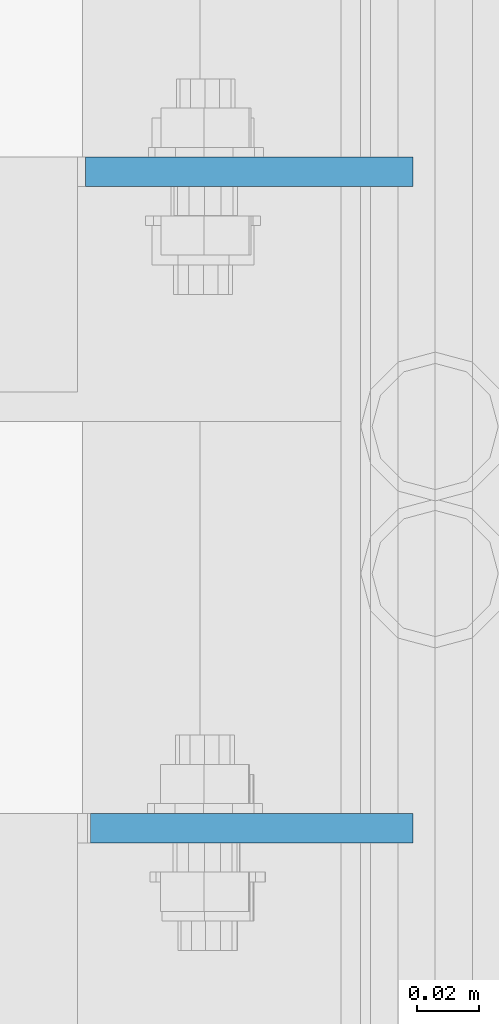
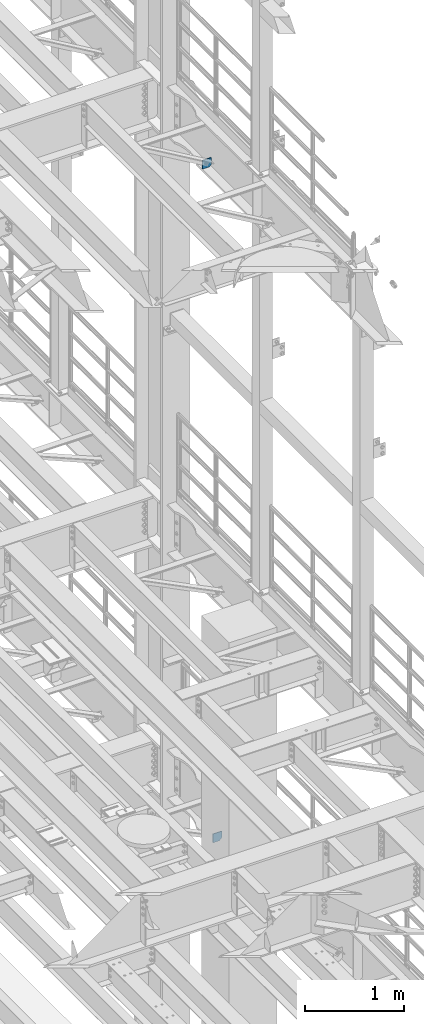
# One storey, part 1728 of 1876: 2 plates, 2 elements without a shape of their own.
"""IFC2X3 building model written with IfcOpenShell, lengths in millimetres."""

from ifc_helpers import new_model, si_unit, frame, origin_with_axes, place, context, subcontext, project, spatial, faceted_brep, material, type_object, element, aggregate, save


model = new_model("IFC2X3")

# Units and contexts
model_context = context("Model", 3, precision=1e-05, world=origin_with_axes())
body_context = subcontext(model_context, "Body", "Model", "MODEL_VIEW")
ifc_project = project(units=[si_unit("LENGTHUNIT", "METRE", prefix="MILLI"), si_unit("AREAUNIT", "SQUARE_METRE"), si_unit("VOLUMEUNIT", "CUBIC_METRE"), si_unit("MASSUNIT", "GRAM", prefix="KILO"), si_unit("TIMEUNIT", "SECOND"), si_unit("PLANEANGLEUNIT", "RADIAN"), si_unit("SOLIDANGLEUNIT", "STERADIAN"), si_unit("THERMODYNAMICTEMPERATUREUNIT", "DEGREE_CELSIUS"), si_unit("LUMINOUSINTENSITYUNIT", "LUMEN")], contexts=[model_context])

# Site, building, storey
site_placement = place(None, origin_with_axes())
site = spatial("IfcSite", under=ifc_project, at=site_placement, CompositionType="ELEMENT")
building_placement = place(site_placement, origin_with_axes())
building = spatial("IfcBuilding", under=site, at=building_placement, Name="Undefined", CompositionType="ELEMENT")
storey_placement = place(building_placement, origin_with_axes())
storey = spatial("IfcBuildingStorey", under=building, at=storey_placement, Name="Undefined", CompositionType="ELEMENT", Elevation=0.0)

# Assembly, plate
assembly_1_placement = place(storey_placement, origin_with_axes())
assembly_1 = element("IfcElementAssembly", 1, at=assembly_1_placement, inside=storey, Name="BEAM", AssemblyPlace="NOTDEFINED", PredefinedType="RIGID_FRAME")
ifc_material = material(Name="STEEL/A36")
plate_type_1 = type_object("IfcPlateType", PredefinedType="NOTDEFINED")
plate_1_placement = place(assembly_1_placement, frame((7508.34074252197, 6396.0375, 4641.9553873822), z_axis=(1.0, 0.0, 0.0), x_axis=(0.0, 0.0, -1.0)))
plate_1 = element("IfcPlate", 2, at=plate_1_placement, type_object=plate_type_1, material=ifc_material, Name="PLATE", context=body_context, shape_type="Brep", body=[
    faceted_brep([(0.0, -4.76249999999982, 0.0), (0.0, -4.76249999999982, 104.515510559082), (0.0, 4.76249999999982, 104.515510559082), (0.0, 4.76249999999982, 0.0), (76.3053894042969, -4.76249999999982, 104.515510559082), (76.3053894042969, 4.76249999999982, 104.515510559082), (108.055389404297, -4.76249999999982, 72.765510559082), (108.055389404297, 4.76249999999982, 72.765510559082), (108.055389404297, -4.76249999999982, 0.0), (108.055389404297, 4.76249999999982, 0.0)], [[[0, 1, 2, 3]], [[1, 4, 5, 2]], [[4, 6, 7, 5]], [[6, 8, 9, 7]], [[8, 0, 3, 9]], [[5, 7, 9, 3, 2]], [[8, 6, 4, 1, 0]]]),
])
aggregate(assembly_1, [plate_1])

assembly_2_placement = place(storey_placement, origin_with_axes())
assembly_2 = element("IfcElementAssembly", 3, at=assembly_2_placement, inside=storey, Name="BEAM", AssemblyPlace="NOTDEFINED", PredefinedType="RIGID_FRAME")
plate_type_2 = type_object("IfcPlateType", PredefinedType="NOTDEFINED")
plate_2_placement = place(assembly_2_placement, frame((7612.85625015191, 6608.76249999999, 12819.726415621), z_axis=(0.0, 0.0, -1.0), x_axis=(-1.0, 0.0, 0.0)))
plate_2 = element("IfcPlate", 4, at=plate_2_placement, type_object=plate_type_2, material=ifc_material, Name="PLATE", context=body_context, shape_type="Brep", body=[
    faceted_brep([(0.0, -4.76249999999982, 0.0), (-3.57139560946962e-06, -4.76249999999982, 81.6264114379865), (-3.57139560946962e-06, 4.76249999999982, 81.6264114379865), (0.0, 4.76249999999982, 0.0), (25.3999958038776, -4.76249999999982, 107.026412963854), (25.3999958038776, 4.76249999999982, 107.026412963854), (106.188095092818, -4.76249999999982, 107.02641296382), (106.188095092818, 4.76249999999982, 107.02641296382), (106.188095092773, -4.76249999999982, -7.27595761418343e-11), (106.188095092773, 4.76249999999982, -7.27595761418343e-11)], [[[0, 1, 2, 3]], [[1, 4, 5, 2]], [[4, 6, 7, 5]], [[6, 8, 9, 7]], [[8, 0, 3, 9]], [[5, 7, 9, 3, 2]], [[8, 6, 4, 1, 0]]]),
])
aggregate(assembly_2, [plate_2])

save(model, "model.ifc")
